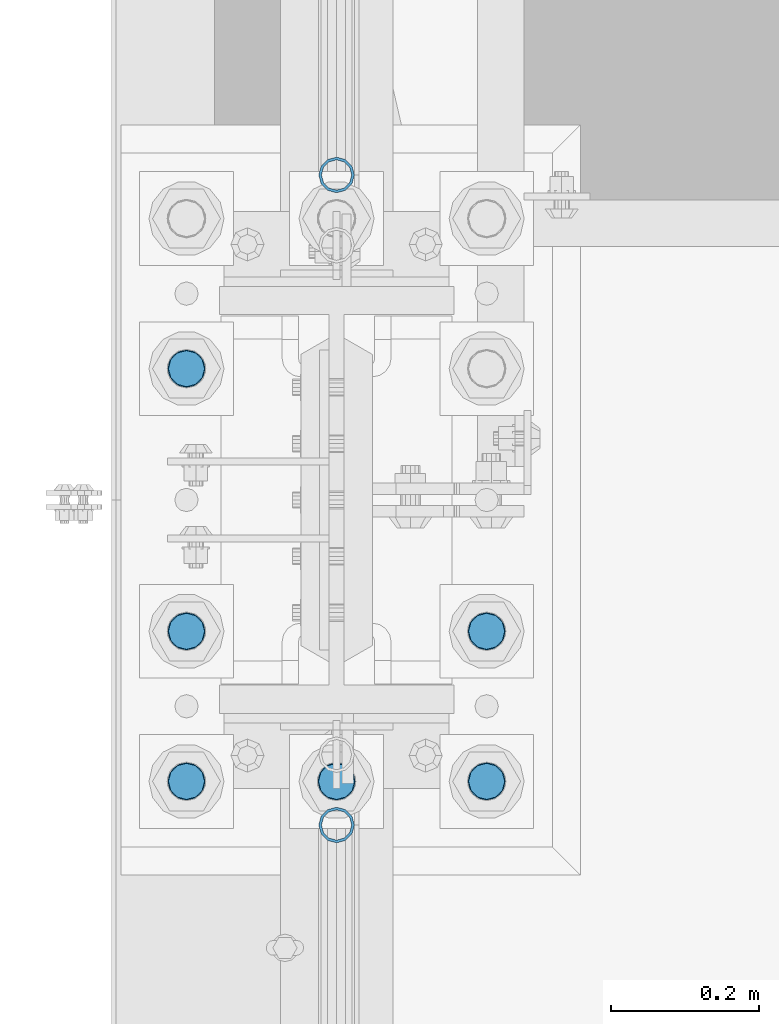
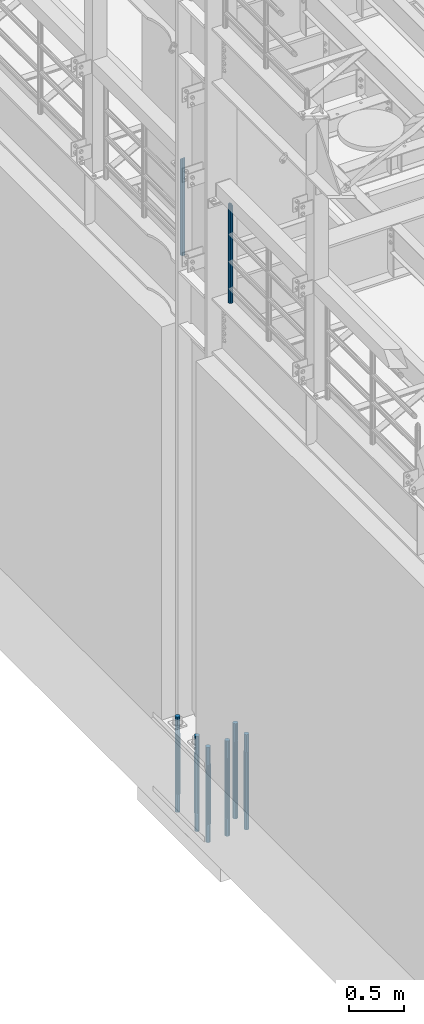
# One storey, part 687 of 1876: 8 columns, 3 elements without a shape of their own.
"""IFC2X3 building model written with IfcOpenShell, lengths in millimetres."""

from ifc_helpers import new_model, si_unit, frame, origin_with_axes, place, context, subcontext, project, spatial, faceted_brep, material, type_object, element, aggregate, save


model = new_model("IFC2X3")

# Units and contexts
model_context = context("Model", 3, precision=1e-05, world=origin_with_axes())
body_context = subcontext(model_context, "Body", "Model", "MODEL_VIEW")
ifc_project = project(units=[si_unit("LENGTHUNIT", "METRE", prefix="MILLI"), si_unit("AREAUNIT", "SQUARE_METRE"), si_unit("VOLUMEUNIT", "CUBIC_METRE"), si_unit("MASSUNIT", "GRAM", prefix="KILO"), si_unit("TIMEUNIT", "SECOND"), si_unit("PLANEANGLEUNIT", "RADIAN"), si_unit("SOLIDANGLEUNIT", "STERADIAN"), si_unit("THERMODYNAMICTEMPERATUREUNIT", "DEGREE_CELSIUS"), si_unit("LUMINOUSINTENSITYUNIT", "LUMEN")], contexts=[model_context])

# Site, building, storey
site_placement = place(None, origin_with_axes())
site = spatial("IfcSite", under=ifc_project, at=site_placement, CompositionType="ELEMENT")
building_placement = place(site_placement, origin_with_axes())
building = spatial("IfcBuilding", under=site, at=building_placement, Name="Undefined", CompositionType="ELEMENT")
storey_placement = place(building_placement, origin_with_axes())
storey = spatial("IfcBuildingStorey", under=building, at=storey_placement, Name="Undefined", CompositionType="ELEMENT", Elevation=0.0)

# Assembly, column
assembly_1_placement = place(storey_placement, origin_with_axes())
assembly_1 = element("IfcElementAssembly", 1, at=assembly_1_placement, inside=storey, Name="RAIL", AssemblyPlace="NOTDEFINED", PredefinedType="RIGID_FRAME")
ifc_material_1 = material()
column_type_1 = type_object("IfcColumnType", Name="PIPE1-1/2SCH40", PredefinedType="NOTDEFINED")
column_1_placement = place(assembly_1_placement, frame((-1.81898940354586e-12, 1964.055, 5130.8), z_axis=(0.0, 1.0, 0.0), x_axis=(0.0, 0.0, 1.0)))
column_1 = element("IfcColumn", 2, at=column_1_placement, type_object=column_type_1, material=ifc_material_1, Name="POST", ObjectType="PIPE1-1/2SCH40", context=body_context, shape_type="Brep", body=[
    faceted_brep([(0.0, -20.4469999999999, 0.0), (0.0, -17.7076214311803, 10.2235000000001), (1066.1015, -17.7076214311803, 10.2235000000001), (1076.325, -20.4469999999999, 0.0), (0.0, -10.2235000000001, 17.7076214311801), (1058.61737856882, -10.2235000000001, 17.7076214311801), (-1.45519152283669e-11, 0.0, 20.4470000000001), (1055.878, 0.0, 20.4470000000001), (0.0, 10.2235000000001, 17.7076214311801), (1058.61737856882, 10.2235000000001, 17.7076214311801), (0.0, 17.7076214311803, 10.2235000000001), (1066.1015, 17.7076214311803, 10.2235000000001), (0.0, 20.4469999999999, 0.0), (1076.325, 20.4469999999999, 0.0), (0.0, 17.7076214311803, -10.2235000000001), (1086.5485, 17.7076214311803, -10.2235000000001), (0.0, 10.2235000000001, -17.7076214311801), (1094.03262143118, 10.2235000000001, -17.7076214311801), (-1.45519152283669e-11, 0.0, -20.4470000000001), (1096.772, 0.0, -20.4470000000001), (0.0, -10.2235000000001, -17.7076214311801), (1094.03262143118, -10.2235000000001, -17.7076214311801), (0.0, -17.7076214311803, -10.2235000000001), (1086.5485, -17.7076214311803, -10.2235000000001), (0.0, -24.1299999999992, 0.0), (0.0, -20.8971929933184, -12.0649999999996), (1088.39, -20.8971929933184, -12.0649999999996), (1076.325, -24.1300000000001, 0.0), (0.0, -12.0650000000001, -20.8971929933186), (1097.22219299332, -12.0650000000001, -20.8971929933186), (-1.45519152283669e-11, 0.0, -24.130000000001), (1100.455, 0.0, -24.1300000000001), (0.0, 12.0650000000001, -20.8971929933186), (1097.22219299332, 12.0650000000001, -20.8971929933186), (0.0, 20.8971929933184, -12.0649999999996), (1088.39, 20.8971929933184, -12.0649999999996), (0.0, 24.1299999999992, 0.0), (1076.325, 24.1300000000001, 0.0), (0.0, 20.8971929933184, 12.0649999999996), (1064.26, 20.8971929933184, 12.0649999999996), (0.0, 12.0650000000001, 20.8971929933186), (1055.42780700668, 12.0650000000001, 20.8971929933186), (-1.45519152283669e-11, 0.0, 24.130000000001), (1052.195, 0.0, 24.1300000000001), (0.0, -12.0650000000001, 20.8971929933186), (1055.42780700668, -12.0650000000001, 20.8971929933186), (0.0, -20.8971929933184, 12.0649999999996), (1064.26, -20.8971929933184, 12.0649999999996)], [[[0, 1, 2, 3]], [[1, 4, 5, 2]], [[4, 6, 7, 5]], [[6, 8, 9, 7]], [[8, 10, 11, 9]], [[10, 12, 13, 11]], [[12, 14, 15, 13]], [[14, 16, 17, 15]], [[16, 18, 19, 17]], [[18, 20, 21, 19]], [[20, 22, 23, 21]], [[22, 0, 3, 23]], [[24, 25, 26, 27]], [[25, 28, 29, 26]], [[28, 30, 31, 29]], [[30, 32, 33, 31]], [[32, 34, 35, 33]], [[34, 36, 37, 35]], [[36, 38, 39, 37]], [[38, 40, 41, 39]], [[40, 42, 43, 41]], [[42, 44, 45, 43]], [[44, 46, 47, 45]], [[46, 24, 27, 47]], [[29, 31, 33, 35, 37, 39, 41, 43, 45, 47, 27, 26], [5, 7, 9, 11, 13, 15, 17, 19, 21, 23, 3, 2]], [[46, 44, 42, 40, 38, 36, 34, 32, 30, 28, 25, 24], [22, 20, 18, 16, 14, 12, 10, 8, 6, 4, 1, 0]]]),
])
aggregate(assembly_1, [column_1])

assembly_2_placement = place(storey_placement, origin_with_axes())
assembly_2 = element("IfcElementAssembly", 3, at=assembly_2_placement, inside=storey, Name="RAIL", AssemblyPlace="NOTDEFINED", PredefinedType="RIGID_FRAME")
column_2_placement = place(assembly_2_placement, frame((-1.81898940354586e-12, 1083.9096633614, 5130.81182459913), z_axis=(0.0, 1.0, 0.0), x_axis=(0.0, 0.0, 1.0)))
column_2 = element("IfcColumn", 4, at=column_2_placement, type_object=column_type_1, material=ifc_material_1, Name="POST", ObjectType="PIPE1-1/2SCH40", context=body_context, shape_type="Brep", body=[
    faceted_brep([(0.0, -20.4469999999999, 0.0), (0.0, -17.7076214311803, 10.2235000000001), (1086.54858618554, -17.7076214311801, 10.2235000000001), (1076.325, -20.4469999999999, 0.0), (0.0, -10.2235000000001, 17.7076214311801), (1094.03277070908, -10.2235000000001, 17.7076214311801), (-1.45519152283669e-11, 0.0, 20.4470000000001), (1096.7721723713, 0.0, 20.4470000000001), (0.0, 10.2235000000001, 17.7076214311801), (1094.03277070908, 10.2235000000001, 17.7076214311801), (0.0, 17.7076214311803, 10.2235000000001), (1086.54858618554, 17.7076214311801, 10.2235000000001), (0.0, 20.4469999999999, 0.0), (1076.325, 20.4469999999999, 0.0), (0.0, 17.7076214311803, -10.2235000000001), (1066.101413814, 17.7076214311801, -10.2235000000001), (0.0, 10.2235000000001, -17.7076214311801), (1058.61722929046, 10.2235000000001, -17.7076214311801), (-1.45519152283669e-11, 0.0, -20.4470000000001), (1055.87782762823, 0.0, -20.4470000000001), (0.0, -10.2235000000001, -17.7076214311801), (1058.61722929046, -10.2235000000001, -17.7076214311801), (0.0, -17.7076214311803, -10.2235000000001), (1066.101413814, -17.7076214311801, -10.2235000000001), (0.0, -24.1299999999992, 0.0), (0.0, -20.8971929933184, -12.0649999999996), (1064.25989828953, -20.8971929933186, -12.0650000000001), (1076.325, -24.1300000000001, 0.0), (0.0, -12.0650000000001, -20.8971929933186), (1055.42763084051, -12.0649999999996, -20.8971929933186), (-1.45519152283669e-11, 0.0, -24.130000000001), (1052.19479658115, 0.0, -24.1300000000001), (0.0, 12.0650000000001, -20.8971929933186), (1055.42763084051, 12.0649999999996, -20.8971929933186), (0.0, 20.8971929933184, -12.0649999999996), (1064.25989828953, 20.8971929933186, -12.0650000000001), (0.0, 24.1299999999992, 0.0), (1076.325, 24.1300000000001, 0.0), (0.0, 20.8971929933184, 12.0649999999996), (1088.39010170968, 20.8971929933186, 12.0649999999996), (0.0, 12.0650000000001, 20.8971929933186), (1097.22236915982, 12.0649999999996, 20.8971929933186), (-1.45519152283669e-11, 0.0, 24.130000000001), (1100.45520341959, 0.0, 24.1300000000001), (0.0, -12.0650000000001, 20.8971929933186), (1097.22236915982, -12.0649999999996, 20.8971929933186), (0.0, -20.8971929933184, 12.0649999999996), (1088.39010170968, -20.8971929933186, 12.0649999999996)], [[[0, 1, 2, 3]], [[1, 4, 5, 2]], [[4, 6, 7, 5]], [[6, 8, 9, 7]], [[8, 10, 11, 9]], [[10, 12, 13, 11]], [[12, 14, 15, 13]], [[14, 16, 17, 15]], [[16, 18, 19, 17]], [[18, 20, 21, 19]], [[20, 22, 23, 21]], [[22, 0, 3, 23]], [[24, 25, 26, 27]], [[25, 28, 29, 26]], [[28, 30, 31, 29]], [[30, 32, 33, 31]], [[32, 34, 35, 33]], [[34, 36, 37, 35]], [[36, 38, 39, 37]], [[38, 40, 41, 39]], [[40, 42, 43, 41]], [[42, 44, 45, 43]], [[44, 46, 47, 45]], [[46, 24, 27, 47]], [[29, 31, 33, 35, 37, 39, 41, 43, 45, 47, 27, 26], [5, 7, 9, 11, 13, 15, 17, 19, 21, 23, 3, 2]], [[46, 44, 42, 40, 38, 36, 34, 32, 30, 28, 25, 24], [22, 20, 18, 16, 14, 12, 10, 8, 6, 4, 1, 0]]]),
])
aggregate(assembly_2, [column_2])

# Assembly, columns
assembly_3_placement = place(storey_placement, origin_with_axes())
assembly_3 = element("IfcElementAssembly", 5, at=assembly_3_placement, inside=storey, Name="TEMPLATE", AssemblyPlace="NOTDEFINED", PredefinedType="RIGID_FRAME")
ifc_material_2 = material(Name="STEEL/F1554-GR.105")
column_type_2 = type_object("IfcColumnType", PredefinedType="NOTDEFINED")
column_3_placement = place(assembly_3_placement, frame((-203.2, 1143.0, 0.0), z_axis=(0.0, -1.0, 0.0), x_axis=(0.0, 0.0, -1.0)))
column_3 = element("IfcColumn", 6, at=column_3_placement, type_object=column_type_2, material=ifc_material_2, Name="ANCHOR_BOLTS", context=body_context, shape_type="Brep", body=[
    faceted_brep([(-196.85, -21.217622392719, 12.25), (-196.85, -12.25, 21.2176223927188), (-196.85, 0.0, 24.5), (-196.85, 12.25, 21.2176223927188), (-196.85, 21.217622392719, 12.25), (-196.85, 24.5, 0.0), (-196.85, 21.217622392719, -12.25), (-196.85, 12.25, -21.2176223927188), (-196.85, 0.0, -24.5), (-196.85, -12.25, -21.2176223927188), (-196.85, -21.217622392719, -12.25), (-196.85, -24.5, 0.0), (0.0, 24.5, 0.0), (0.0, 21.217622392719, -12.25), (0.0, 12.25, -21.2176223927188), (0.0, 0.0, -24.5), (0.0, -12.25, -21.2176223927188), (0.0, -21.217622392719, -12.25), (0.0, -24.5, 0.0), (0.0, -21.217622392719, 12.25), (0.0, -12.25, 21.2176223927188), (0.0, 0.0, 24.5), (0.0, 12.25, 21.2176223927188), (0.0, 21.217622392719, 12.25), (0.0, -23.4665401257871, 9.7201591820733), (0.0, -17.9605122421381, 17.9605122421383), (0.0, -9.72015918207308, 23.4665401257867), (0.0, 0.0, 25.4000000000001), (0.0, 9.72015918207308, 23.4665401257867), (0.0, 17.9605122421381, 17.9605122421383), (0.0, 23.4665401257871, 9.7201591820733), (0.0, 25.3999996185339, 9.09494701772928e-13), (0.0, 23.4665401257871, -9.7201591820733), (0.0, 17.9605122421381, -17.9605122421383), (0.0, 9.72015918207308, -23.4665401257867), (0.0, 0.0, -25.4000000000001), (0.0, -9.72015918207308, -23.4665401257867), (0.0, -17.9605122421381, -17.9605122421383), (0.0, -23.4665401257871, -9.7201591820733), (0.0, -25.3999996185375, 0.0), (673.1, -25.3999999999996, 0.0), (673.1, -23.4665401257871, 9.7201591820733), (673.1, -17.9605122421381, 17.9605122421383), (673.1, -9.72015918207308, 23.4665401257867), (673.1, 0.0, 25.4000000000001), (673.1, 9.72015918207308, 23.4665401257867), (673.1, 17.9605122421381, 17.9605122421383), (673.1, 23.4665401257871, 9.7201591820733), (673.1, 25.3999999999996, 0.0), (673.1, 23.4665401257871, -9.7201591820733), (673.1, 17.9605122421381, -17.9605122421383), (673.1, 9.72015918207308, -23.4665401257867), (673.1, 0.0, -25.4000000000001), (673.1, -9.72015918207308, -23.4665401257867), (673.1, -17.9605122421381, -17.9605122421383), (673.1, -23.4665401257871, -9.7201591820733), (673.1, -12.25, 21.2176223927188), (673.1, 0.0, 24.5), (673.1, 12.25, 21.2176223927188), (673.1, 21.217622392719, 12.25), (673.1, 24.5, 0.0), (673.1, 21.217622392719, -12.25), (673.1, 12.25, -21.2176223927188), (673.1, 0.0, -24.5), (673.1, -12.25, -21.2176223927188), (673.1, -21.217622392719, -12.25), (673.1, -24.5, 0.0), (673.1, -21.217622392719, 12.25), (869.95, -12.25, -21.2176223927188), (869.95, 0.0, -24.5), (869.95, 12.25, -21.2176223927188), (869.95, 21.217622392719, -12.25), (869.95, 24.5, 0.0), (869.95, 21.217622392719, 12.25), (869.95, 12.25, 21.2176223927188), (869.95, 0.0, 24.5), (869.95, -12.25, 21.2176223927188), (869.95, -21.217622392719, 12.25), (869.95, -24.5, 0.0), (869.95, -21.217622392719, -12.25)], [[[0, 1, 2, 3, 4, 5, 6, 7, 8, 9, 10, 11]], [[6, 5, 12, 13]], [[7, 6, 13, 14]], [[8, 7, 14, 15]], [[9, 8, 15, 16]], [[10, 9, 16, 17]], [[11, 10, 17, 18]], [[0, 11, 18, 19]], [[1, 0, 19, 20]], [[2, 1, 20, 21]], [[3, 2, 21, 22]], [[4, 3, 22, 23]], [[5, 4, 23, 12]], [[24, 25, 26, 27, 28, 29, 30, 31, 32, 33, 34, 35, 36, 37, 38, 39], [22, 21, 20, 19, 18, 17, 16, 15, 14, 13, 12, 23]], [[24, 39, 40, 41]], [[25, 24, 41, 42]], [[26, 25, 42, 43]], [[27, 26, 43, 44]], [[28, 27, 44, 45]], [[29, 28, 45, 46]], [[30, 29, 46, 47]], [[31, 30, 47, 48]], [[32, 31, 48, 49]], [[33, 32, 49, 50]], [[34, 33, 50, 51]], [[35, 34, 51, 52]], [[36, 35, 52, 53]], [[37, 36, 53, 54]], [[38, 37, 54, 55]], [[39, 38, 55, 40]], [[54, 53, 52, 51, 50, 49, 48, 47, 46, 45, 44, 43, 42, 41, 40, 55], [56, 57, 58, 59, 60, 61, 62, 63, 64, 65, 66, 67]], [[68, 69, 70, 71, 72, 73, 74, 75, 76, 77, 78, 79]], [[76, 75, 57, 56]], [[77, 76, 56, 67]], [[78, 77, 67, 66]], [[79, 78, 66, 65]], [[68, 79, 65, 64]], [[69, 68, 64, 63]], [[70, 69, 63, 62]], [[71, 70, 62, 61]], [[72, 71, 61, 60]], [[73, 72, 60, 59]], [[74, 73, 59, 58]], [[75, 74, 58, 57]]]),
])
column_4_placement = place(assembly_3_placement, frame((0.0, 1143.0, 0.0), z_axis=(0.0, -1.0, 0.0), x_axis=(0.0, 0.0, -1.0)))
column_4 = element("IfcColumn", 7, at=column_4_placement, type_object=column_type_2, material=ifc_material_2, Name="ANCHOR_BOLTS", context=body_context, shape_type="Brep", body=[
    faceted_brep([(-196.85, -21.217622392719, 12.25), (-196.85, -12.25, 21.2176223927188), (-196.85, 0.0, 24.5), (-196.85, 12.25, 21.2176223927188), (-196.85, 21.217622392719, 12.25), (-196.85, 24.5, 0.0), (-196.85, 21.217622392719, -12.25), (-196.85, 12.25, -21.2176223927188), (-196.85, 0.0, -24.5), (-196.85, -12.25, -21.2176223927188), (-196.85, -21.217622392719, -12.25), (-196.85, -24.5, 0.0), (0.0, 24.5, 0.0), (0.0, 21.217622392719, -12.25), (0.0, 12.25, -21.2176223927188), (0.0, 0.0, -24.5), (0.0, -12.25, -21.2176223927188), (0.0, -21.217622392719, -12.25), (0.0, -24.5, 0.0), (0.0, -21.217622392719, 12.25), (0.0, -12.25, 21.2176223927188), (0.0, 0.0, 24.5), (0.0, 12.25, 21.2176223927188), (0.0, 21.217622392719, 12.25), (0.0, -23.4665401257871, 9.7201591820733), (0.0, -17.9605122421381, 17.9605122421383), (0.0, -9.72015918207308, 23.4665401257867), (0.0, 0.0, 25.4000000000001), (0.0, 9.72015918207308, 23.4665401257867), (0.0, 17.9605122421381, 17.9605122421383), (0.0, 23.4665401257871, 9.7201591820733), (0.0, 25.3999996185339, 9.09494701772928e-13), (0.0, 23.4665401257871, -9.7201591820733), (0.0, 17.9605122421381, -17.9605122421383), (0.0, 9.72015918207308, -23.4665401257867), (0.0, 0.0, -25.4000000000001), (0.0, -9.72015918207308, -23.4665401257867), (0.0, -17.9605122421381, -17.9605122421383), (0.0, -23.4665401257871, -9.7201591820733), (0.0, -25.3999996185375, 0.0), (673.1, -25.3999999999996, 0.0), (673.1, -23.4665401257871, 9.7201591820733), (673.1, -17.9605122421381, 17.9605122421383), (673.1, -9.72015918207308, 23.4665401257867), (673.1, 0.0, 25.4000000000001), (673.1, 9.72015918207308, 23.4665401257867), (673.1, 17.9605122421381, 17.9605122421383), (673.1, 23.4665401257871, 9.7201591820733), (673.1, 25.3999999999996, 0.0), (673.1, 23.4665401257871, -9.7201591820733), (673.1, 17.9605122421381, -17.9605122421383), (673.1, 9.72015918207308, -23.4665401257867), (673.1, 0.0, -25.4000000000001), (673.1, -9.72015918207308, -23.4665401257867), (673.1, -17.9605122421381, -17.9605122421383), (673.1, -23.4665401257871, -9.7201591820733), (673.1, -12.25, 21.2176223927188), (673.1, 0.0, 24.5), (673.1, 12.25, 21.2176223927188), (673.1, 21.217622392719, 12.25), (673.1, 24.5, 0.0), (673.1, 21.217622392719, -12.25), (673.1, 12.25, -21.2176223927188), (673.1, 0.0, -24.5), (673.1, -12.25, -21.2176223927188), (673.1, -21.217622392719, -12.25), (673.1, -24.5, 0.0), (673.1, -21.217622392719, 12.25), (869.95, -12.25, -21.2176223927188), (869.95, 0.0, -24.5), (869.95, 12.25, -21.2176223927188), (869.95, 21.217622392719, -12.25), (869.95, 24.5, 0.0), (869.95, 21.217622392719, 12.25), (869.95, 12.25, 21.2176223927188), (869.95, 0.0, 24.5), (869.95, -12.25, 21.2176223927188), (869.95, -21.217622392719, 12.25), (869.95, -24.5, 0.0), (869.95, -21.217622392719, -12.25)], [[[0, 1, 2, 3, 4, 5, 6, 7, 8, 9, 10, 11]], [[6, 5, 12, 13]], [[7, 6, 13, 14]], [[8, 7, 14, 15]], [[9, 8, 15, 16]], [[10, 9, 16, 17]], [[11, 10, 17, 18]], [[0, 11, 18, 19]], [[1, 0, 19, 20]], [[2, 1, 20, 21]], [[3, 2, 21, 22]], [[4, 3, 22, 23]], [[5, 4, 23, 12]], [[24, 25, 26, 27, 28, 29, 30, 31, 32, 33, 34, 35, 36, 37, 38, 39], [22, 21, 20, 19, 18, 17, 16, 15, 14, 13, 12, 23]], [[24, 39, 40, 41]], [[25, 24, 41, 42]], [[26, 25, 42, 43]], [[27, 26, 43, 44]], [[28, 27, 44, 45]], [[29, 28, 45, 46]], [[30, 29, 46, 47]], [[31, 30, 47, 48]], [[32, 31, 48, 49]], [[33, 32, 49, 50]], [[34, 33, 50, 51]], [[35, 34, 51, 52]], [[36, 35, 52, 53]], [[37, 36, 53, 54]], [[38, 37, 54, 55]], [[39, 38, 55, 40]], [[54, 53, 52, 51, 50, 49, 48, 47, 46, 45, 44, 43, 42, 41, 40, 55], [56, 57, 58, 59, 60, 61, 62, 63, 64, 65, 66, 67]], [[68, 69, 70, 71, 72, 73, 74, 75, 76, 77, 78, 79]], [[76, 75, 57, 56]], [[77, 76, 56, 67]], [[78, 77, 67, 66]], [[79, 78, 66, 65]], [[68, 79, 65, 64]], [[69, 68, 64, 63]], [[70, 69, 63, 62]], [[71, 70, 62, 61]], [[72, 71, 61, 60]], [[73, 72, 60, 59]], [[74, 73, 59, 58]], [[75, 74, 58, 57]]]),
])
column_5_placement = place(assembly_3_placement, frame((203.2, 1143.0, 0.0), z_axis=(0.0, 1.0, 0.0), x_axis=(0.0, 0.0, -1.0)))
column_5 = element("IfcColumn", 8, at=column_5_placement, type_object=column_type_2, material=ifc_material_2, Name="ANCHOR_BOLTS", context=body_context, shape_type="Brep", body=[
    faceted_brep([(-196.85, -21.217622392719, 12.25), (-196.85, -12.25, 21.2176223927188), (-196.85, 0.0, 24.5), (-196.85, 12.25, 21.2176223927188), (-196.85, 21.217622392719, 12.25), (-196.85, 24.5, 0.0), (-196.85, 21.217622392719, -12.25), (-196.85, 12.25, -21.2176223927188), (-196.85, 0.0, -24.5), (-196.85, -12.25, -21.2176223927188), (-196.85, -21.217622392719, -12.25), (-196.85, -24.5, 0.0), (0.0, 24.5, 0.0), (0.0, 21.217622392719, -12.25), (0.0, 12.25, -21.2176223927188), (0.0, 0.0, -24.5), (0.0, -12.25, -21.2176223927188), (0.0, -21.217622392719, -12.25), (0.0, -24.5, 0.0), (0.0, -21.217622392719, 12.25), (0.0, -12.25, 21.2176223927188), (0.0, 0.0, 24.5), (0.0, 12.25, 21.2176223927188), (0.0, 21.217622392719, 12.25), (0.0, -23.4665401257871, 9.7201591820733), (0.0, -17.9605122421381, 17.9605122421383), (0.0, -9.72015918207308, 23.4665401257867), (0.0, 0.0, 25.4000000000001), (0.0, 9.72015918207308, 23.4665401257867), (0.0, 17.9605122421381, 17.9605122421383), (0.0, 23.4665401257871, 9.7201591820733), (0.0, 25.3999996185339, 9.09494701772928e-13), (0.0, 23.4665401257871, -9.7201591820733), (0.0, 17.9605122421381, -17.9605122421383), (0.0, 9.72015918207308, -23.4665401257867), (0.0, 0.0, -25.4000000000001), (0.0, -9.72015918207308, -23.4665401257867), (0.0, -17.9605122421381, -17.9605122421383), (0.0, -23.4665401257871, -9.7201591820733), (0.0, -25.3999996185375, 0.0), (673.1, -25.3999999999996, 0.0), (673.1, -23.4665401257871, 9.7201591820733), (673.1, -17.9605122421381, 17.9605122421383), (673.1, -9.72015918207308, 23.4665401257867), (673.1, 0.0, 25.4000000000001), (673.1, 9.72015918207308, 23.4665401257867), (673.1, 17.9605122421381, 17.9605122421383), (673.1, 23.4665401257871, 9.7201591820733), (673.1, 25.3999999999996, 0.0), (673.1, 23.4665401257871, -9.7201591820733), (673.1, 17.9605122421381, -17.9605122421383), (673.1, 9.72015918207308, -23.4665401257867), (673.1, 0.0, -25.4000000000001), (673.1, -9.72015918207308, -23.4665401257867), (673.1, -17.9605122421381, -17.9605122421383), (673.1, -23.4665401257871, -9.7201591820733), (673.1, -12.25, 21.2176223927188), (673.1, 0.0, 24.5), (673.1, 12.25, 21.2176223927188), (673.1, 21.217622392719, 12.25), (673.1, 24.5, 0.0), (673.1, 21.217622392719, -12.25), (673.1, 12.25, -21.2176223927188), (673.1, 0.0, -24.5), (673.1, -12.25, -21.2176223927188), (673.1, -21.217622392719, -12.25), (673.1, -24.5, 0.0), (673.1, -21.217622392719, 12.25), (869.95, -12.25, -21.2176223927188), (869.95, 0.0, -24.5), (869.95, 12.25, -21.2176223927188), (869.95, 21.217622392719, -12.25), (869.95, 24.5, 0.0), (869.95, 21.217622392719, 12.25), (869.95, 12.25, 21.2176223927188), (869.95, 0.0, 24.5), (869.95, -12.25, 21.2176223927188), (869.95, -21.217622392719, 12.25), (869.95, -24.5, 0.0), (869.95, -21.217622392719, -12.25)], [[[0, 1, 2, 3, 4, 5, 6, 7, 8, 9, 10, 11]], [[6, 5, 12, 13]], [[7, 6, 13, 14]], [[8, 7, 14, 15]], [[9, 8, 15, 16]], [[10, 9, 16, 17]], [[11, 10, 17, 18]], [[0, 11, 18, 19]], [[1, 0, 19, 20]], [[2, 1, 20, 21]], [[3, 2, 21, 22]], [[4, 3, 22, 23]], [[5, 4, 23, 12]], [[24, 25, 26, 27, 28, 29, 30, 31, 32, 33, 34, 35, 36, 37, 38, 39], [22, 21, 20, 19, 18, 17, 16, 15, 14, 13, 12, 23]], [[24, 39, 40, 41]], [[25, 24, 41, 42]], [[26, 25, 42, 43]], [[27, 26, 43, 44]], [[28, 27, 44, 45]], [[29, 28, 45, 46]], [[30, 29, 46, 47]], [[31, 30, 47, 48]], [[32, 31, 48, 49]], [[33, 32, 49, 50]], [[34, 33, 50, 51]], [[35, 34, 51, 52]], [[36, 35, 52, 53]], [[37, 36, 53, 54]], [[38, 37, 54, 55]], [[39, 38, 55, 40]], [[54, 53, 52, 51, 50, 49, 48, 47, 46, 45, 44, 43, 42, 41, 40, 55], [56, 57, 58, 59, 60, 61, 62, 63, 64, 65, 66, 67]], [[68, 69, 70, 71, 72, 73, 74, 75, 76, 77, 78, 79]], [[76, 75, 57, 56]], [[77, 76, 56, 67]], [[78, 77, 67, 66]], [[79, 78, 66, 65]], [[68, 79, 65, 64]], [[69, 68, 64, 63]], [[70, 69, 63, 62]], [[71, 70, 62, 61]], [[72, 71, 61, 60]], [[73, 72, 60, 59]], [[74, 73, 59, 58]], [[75, 74, 58, 57]]]),
])
column_6_placement = place(assembly_3_placement, frame((-203.2, 1346.2, 0.0), z_axis=(0.0, -1.0, 0.0), x_axis=(0.0, 0.0, -1.0)))
column_6 = element("IfcColumn", 9, at=column_6_placement, type_object=column_type_2, material=ifc_material_2, Name="ANCHOR_BOLTS", context=body_context, shape_type="Brep", body=[
    faceted_brep([(-196.85, -21.217622392719, 12.25), (-196.85, -12.25, 21.2176223927188), (-196.85, 0.0, 24.5), (-196.85, 12.25, 21.2176223927188), (-196.85, 21.217622392719, 12.25), (-196.85, 24.5, 0.0), (-196.85, 21.217622392719, -12.25), (-196.85, 12.25, -21.2176223927188), (-196.85, 0.0, -24.5), (-196.85, -12.25, -21.2176223927188), (-196.85, -21.217622392719, -12.25), (-196.85, -24.5, 0.0), (0.0, 24.5, 0.0), (0.0, 21.217622392719, -12.25), (0.0, 12.25, -21.2176223927188), (0.0, 0.0, -24.5), (0.0, -12.25, -21.2176223927188), (0.0, -21.217622392719, -12.25), (0.0, -24.5, 0.0), (0.0, -21.217622392719, 12.25), (0.0, -12.25, 21.2176223927188), (0.0, 0.0, 24.5), (0.0, 12.25, 21.2176223927188), (0.0, 21.217622392719, 12.25), (0.0, -23.4665401257871, 9.7201591820733), (0.0, -17.9605122421381, 17.9605122421383), (0.0, -9.72015918207308, 23.4665401257867), (0.0, 0.0, 25.4000000000001), (0.0, 9.72015918207308, 23.4665401257867), (0.0, 17.9605122421381, 17.9605122421383), (0.0, 23.4665401257871, 9.7201591820733), (0.0, 25.3999996185339, 9.09494701772928e-13), (0.0, 23.4665401257871, -9.7201591820733), (0.0, 17.9605122421381, -17.9605122421383), (0.0, 9.72015918207308, -23.4665401257867), (0.0, 0.0, -25.4000000000001), (0.0, -9.72015918207308, -23.4665401257867), (0.0, -17.9605122421381, -17.9605122421383), (0.0, -23.4665401257871, -9.7201591820733), (0.0, -25.3999996185375, 0.0), (673.1, -25.3999999999996, 0.0), (673.1, -23.4665401257871, 9.7201591820733), (673.1, -17.9605122421381, 17.9605122421383), (673.1, -9.72015918207308, 23.4665401257867), (673.1, 0.0, 25.4000000000001), (673.1, 9.72015918207308, 23.4665401257867), (673.1, 17.9605122421381, 17.9605122421383), (673.1, 23.4665401257871, 9.7201591820733), (673.1, 25.3999999999996, 0.0), (673.1, 23.4665401257871, -9.7201591820733), (673.1, 17.9605122421381, -17.9605122421383), (673.1, 9.72015918207308, -23.4665401257867), (673.1, 0.0, -25.4000000000001), (673.1, -9.72015918207308, -23.4665401257867), (673.1, -17.9605122421381, -17.9605122421383), (673.1, -23.4665401257871, -9.7201591820733), (673.1, -12.25, 21.2176223927188), (673.1, 0.0, 24.5), (673.1, 12.25, 21.2176223927188), (673.1, 21.217622392719, 12.25), (673.1, 24.5, 0.0), (673.1, 21.217622392719, -12.25), (673.1, 12.25, -21.2176223927188), (673.1, 0.0, -24.5), (673.1, -12.25, -21.2176223927188), (673.1, -21.217622392719, -12.25), (673.1, -24.5, 0.0), (673.1, -21.217622392719, 12.25), (869.95, -12.25, -21.2176223927188), (869.95, 0.0, -24.5), (869.95, 12.25, -21.2176223927188), (869.95, 21.217622392719, -12.25), (869.95, 24.5, 0.0), (869.95, 21.217622392719, 12.25), (869.95, 12.25, 21.2176223927188), (869.95, 0.0, 24.5), (869.95, -12.25, 21.2176223927188), (869.95, -21.217622392719, 12.25), (869.95, -24.5, 0.0), (869.95, -21.217622392719, -12.25)], [[[0, 1, 2, 3, 4, 5, 6, 7, 8, 9, 10, 11]], [[6, 5, 12, 13]], [[7, 6, 13, 14]], [[8, 7, 14, 15]], [[9, 8, 15, 16]], [[10, 9, 16, 17]], [[11, 10, 17, 18]], [[0, 11, 18, 19]], [[1, 0, 19, 20]], [[2, 1, 20, 21]], [[3, 2, 21, 22]], [[4, 3, 22, 23]], [[5, 4, 23, 12]], [[24, 25, 26, 27, 28, 29, 30, 31, 32, 33, 34, 35, 36, 37, 38, 39], [22, 21, 20, 19, 18, 17, 16, 15, 14, 13, 12, 23]], [[24, 39, 40, 41]], [[25, 24, 41, 42]], [[26, 25, 42, 43]], [[27, 26, 43, 44]], [[28, 27, 44, 45]], [[29, 28, 45, 46]], [[30, 29, 46, 47]], [[31, 30, 47, 48]], [[32, 31, 48, 49]], [[33, 32, 49, 50]], [[34, 33, 50, 51]], [[35, 34, 51, 52]], [[36, 35, 52, 53]], [[37, 36, 53, 54]], [[38, 37, 54, 55]], [[39, 38, 55, 40]], [[54, 53, 52, 51, 50, 49, 48, 47, 46, 45, 44, 43, 42, 41, 40, 55], [56, 57, 58, 59, 60, 61, 62, 63, 64, 65, 66, 67]], [[68, 69, 70, 71, 72, 73, 74, 75, 76, 77, 78, 79]], [[76, 75, 57, 56]], [[77, 76, 56, 67]], [[78, 77, 67, 66]], [[79, 78, 66, 65]], [[68, 79, 65, 64]], [[69, 68, 64, 63]], [[70, 69, 63, 62]], [[71, 70, 62, 61]], [[72, 71, 61, 60]], [[73, 72, 60, 59]], [[74, 73, 59, 58]], [[75, 74, 58, 57]]]),
])
column_7_placement = place(assembly_3_placement, frame((203.2, 1346.2, 0.0), z_axis=(0.0, 1.0, 0.0), x_axis=(0.0, 0.0, -1.0)))
column_7 = element("IfcColumn", 10, at=column_7_placement, type_object=column_type_2, material=ifc_material_2, Name="ANCHOR_BOLTS", context=body_context, shape_type="Brep", body=[
    faceted_brep([(-196.85, -21.217622392719, 12.25), (-196.85, -12.25, 21.2176223927188), (-196.85, 0.0, 24.5), (-196.85, 12.25, 21.2176223927188), (-196.85, 21.217622392719, 12.25), (-196.85, 24.5, 0.0), (-196.85, 21.217622392719, -12.25), (-196.85, 12.25, -21.2176223927188), (-196.85, 0.0, -24.5), (-196.85, -12.25, -21.2176223927188), (-196.85, -21.217622392719, -12.25), (-196.85, -24.5, 0.0), (0.0, 24.5, 0.0), (0.0, 21.217622392719, -12.25), (0.0, 12.25, -21.2176223927188), (0.0, 0.0, -24.5), (0.0, -12.25, -21.2176223927188), (0.0, -21.217622392719, -12.25), (0.0, -24.5, 0.0), (0.0, -21.217622392719, 12.25), (0.0, -12.25, 21.2176223927188), (0.0, 0.0, 24.5), (0.0, 12.25, 21.2176223927188), (0.0, 21.217622392719, 12.25), (0.0, -23.4665401257871, 9.7201591820733), (0.0, -17.9605122421381, 17.9605122421383), (0.0, -9.72015918207308, 23.4665401257867), (0.0, 0.0, 25.4000000000001), (0.0, 9.72015918207308, 23.4665401257867), (0.0, 17.9605122421381, 17.9605122421383), (0.0, 23.4665401257871, 9.7201591820733), (0.0, 25.3999996185339, 9.09494701772928e-13), (0.0, 23.4665401257871, -9.7201591820733), (0.0, 17.9605122421381, -17.9605122421383), (0.0, 9.72015918207308, -23.4665401257867), (0.0, 0.0, -25.4000000000001), (0.0, -9.72015918207308, -23.4665401257867), (0.0, -17.9605122421381, -17.9605122421383), (0.0, -23.4665401257871, -9.7201591820733), (0.0, -25.3999996185375, 0.0), (673.1, -25.3999999999996, 0.0), (673.1, -23.4665401257871, 9.7201591820733), (673.1, -17.9605122421381, 17.9605122421383), (673.1, -9.72015918207308, 23.4665401257867), (673.1, 0.0, 25.4000000000001), (673.1, 9.72015918207308, 23.4665401257867), (673.1, 17.9605122421381, 17.9605122421383), (673.1, 23.4665401257871, 9.7201591820733), (673.1, 25.3999999999996, 0.0), (673.1, 23.4665401257871, -9.7201591820733), (673.1, 17.9605122421381, -17.9605122421383), (673.1, 9.72015918207308, -23.4665401257867), (673.1, 0.0, -25.4000000000001), (673.1, -9.72015918207308, -23.4665401257867), (673.1, -17.9605122421381, -17.9605122421383), (673.1, -23.4665401257871, -9.7201591820733), (673.1, -12.25, 21.2176223927188), (673.1, 0.0, 24.5), (673.1, 12.25, 21.2176223927188), (673.1, 21.217622392719, 12.25), (673.1, 24.5, 0.0), (673.1, 21.217622392719, -12.25), (673.1, 12.25, -21.2176223927188), (673.1, 0.0, -24.5), (673.1, -12.25, -21.2176223927188), (673.1, -21.217622392719, -12.25), (673.1, -24.5, 0.0), (673.1, -21.217622392719, 12.25), (869.95, -12.25, -21.2176223927188), (869.95, 0.0, -24.5), (869.95, 12.25, -21.2176223927188), (869.95, 21.217622392719, -12.25), (869.95, 24.5, 0.0), (869.95, 21.217622392719, 12.25), (869.95, 12.25, 21.2176223927188), (869.95, 0.0, 24.5), (869.95, -12.25, 21.2176223927188), (869.95, -21.217622392719, 12.25), (869.95, -24.5, 0.0), (869.95, -21.217622392719, -12.25)], [[[0, 1, 2, 3, 4, 5, 6, 7, 8, 9, 10, 11]], [[6, 5, 12, 13]], [[7, 6, 13, 14]], [[8, 7, 14, 15]], [[9, 8, 15, 16]], [[10, 9, 16, 17]], [[11, 10, 17, 18]], [[0, 11, 18, 19]], [[1, 0, 19, 20]], [[2, 1, 20, 21]], [[3, 2, 21, 22]], [[4, 3, 22, 23]], [[5, 4, 23, 12]], [[24, 25, 26, 27, 28, 29, 30, 31, 32, 33, 34, 35, 36, 37, 38, 39], [22, 21, 20, 19, 18, 17, 16, 15, 14, 13, 12, 23]], [[24, 39, 40, 41]], [[25, 24, 41, 42]], [[26, 25, 42, 43]], [[27, 26, 43, 44]], [[28, 27, 44, 45]], [[29, 28, 45, 46]], [[30, 29, 46, 47]], [[31, 30, 47, 48]], [[32, 31, 48, 49]], [[33, 32, 49, 50]], [[34, 33, 50, 51]], [[35, 34, 51, 52]], [[36, 35, 52, 53]], [[37, 36, 53, 54]], [[38, 37, 54, 55]], [[39, 38, 55, 40]], [[54, 53, 52, 51, 50, 49, 48, 47, 46, 45, 44, 43, 42, 41, 40, 55], [56, 57, 58, 59, 60, 61, 62, 63, 64, 65, 66, 67]], [[68, 69, 70, 71, 72, 73, 74, 75, 76, 77, 78, 79]], [[76, 75, 57, 56]], [[77, 76, 56, 67]], [[78, 77, 67, 66]], [[79, 78, 66, 65]], [[68, 79, 65, 64]], [[69, 68, 64, 63]], [[70, 69, 63, 62]], [[71, 70, 62, 61]], [[72, 71, 61, 60]], [[73, 72, 60, 59]], [[74, 73, 59, 58]], [[75, 74, 58, 57]]]),
])
column_8_placement = place(assembly_3_placement, frame((-203.2, 1701.8, 0.0), z_axis=(0.0, -1.0, 0.0), x_axis=(0.0, 0.0, -1.0)))
column_8 = element("IfcColumn", 11, at=column_8_placement, type_object=column_type_2, material=ifc_material_2, Name="ANCHOR_BOLTS", context=body_context, shape_type="Brep", body=[
    faceted_brep([(-196.85, -21.217622392719, 12.25), (-196.85, -12.25, 21.2176223927188), (-196.85, 0.0, 24.5), (-196.85, 12.25, 21.2176223927188), (-196.85, 21.217622392719, 12.25), (-196.85, 24.5, 0.0), (-196.85, 21.217622392719, -12.25), (-196.85, 12.25, -21.2176223927188), (-196.85, 0.0, -24.5), (-196.85, -12.25, -21.2176223927188), (-196.85, -21.217622392719, -12.25), (-196.85, -24.5, 0.0), (0.0, 24.5, 0.0), (0.0, 21.217622392719, -12.25), (0.0, 12.25, -21.2176223927188), (0.0, 0.0, -24.5), (0.0, -12.25, -21.2176223927188), (0.0, -21.217622392719, -12.25), (0.0, -24.5, 0.0), (0.0, -21.217622392719, 12.25), (0.0, -12.25, 21.2176223927188), (0.0, 0.0, 24.5), (0.0, 12.25, 21.2176223927188), (0.0, 21.217622392719, 12.25), (0.0, -23.4665401257871, 9.7201591820733), (0.0, -17.9605122421381, 17.9605122421383), (0.0, -9.72015918207308, 23.4665401257867), (0.0, 0.0, 25.4000000000001), (0.0, 9.72015918207308, 23.4665401257867), (0.0, 17.9605122421381, 17.9605122421383), (0.0, 23.4665401257871, 9.7201591820733), (0.0, 25.3999996185339, 9.09494701772928e-13), (0.0, 23.4665401257871, -9.7201591820733), (0.0, 17.9605122421381, -17.9605122421383), (0.0, 9.72015918207308, -23.4665401257867), (0.0, 0.0, -25.4000000000001), (0.0, -9.72015918207308, -23.4665401257867), (0.0, -17.9605122421381, -17.9605122421383), (0.0, -23.4665401257871, -9.7201591820733), (0.0, -25.3999996185375, 0.0), (673.1, -25.3999999999996, 0.0), (673.1, -23.4665401257871, 9.7201591820733), (673.1, -17.9605122421381, 17.9605122421383), (673.1, -9.72015918207308, 23.4665401257867), (673.1, 0.0, 25.4000000000001), (673.1, 9.72015918207308, 23.4665401257867), (673.1, 17.9605122421381, 17.9605122421383), (673.1, 23.4665401257871, 9.7201591820733), (673.1, 25.3999999999996, 0.0), (673.1, 23.4665401257871, -9.7201591820733), (673.1, 17.9605122421381, -17.9605122421383), (673.1, 9.72015918207308, -23.4665401257867), (673.1, 0.0, -25.4000000000001), (673.1, -9.72015918207308, -23.4665401257867), (673.1, -17.9605122421381, -17.9605122421383), (673.1, -23.4665401257871, -9.7201591820733), (673.1, -12.25, 21.2176223927188), (673.1, 0.0, 24.5), (673.1, 12.25, 21.2176223927188), (673.1, 21.217622392719, 12.25), (673.1, 24.5, 0.0), (673.1, 21.217622392719, -12.25), (673.1, 12.25, -21.2176223927188), (673.1, 0.0, -24.5), (673.1, -12.25, -21.2176223927188), (673.1, -21.217622392719, -12.25), (673.1, -24.5, 0.0), (673.1, -21.217622392719, 12.25), (869.95, -12.25, -21.2176223927188), (869.95, 0.0, -24.5), (869.95, 12.25, -21.2176223927188), (869.95, 21.217622392719, -12.25), (869.95, 24.5, 0.0), (869.95, 21.217622392719, 12.25), (869.95, 12.25, 21.2176223927188), (869.95, 0.0, 24.5), (869.95, -12.25, 21.2176223927188), (869.95, -21.217622392719, 12.25), (869.95, -24.5, 0.0), (869.95, -21.217622392719, -12.25)], [[[0, 1, 2, 3, 4, 5, 6, 7, 8, 9, 10, 11]], [[6, 5, 12, 13]], [[7, 6, 13, 14]], [[8, 7, 14, 15]], [[9, 8, 15, 16]], [[10, 9, 16, 17]], [[11, 10, 17, 18]], [[0, 11, 18, 19]], [[1, 0, 19, 20]], [[2, 1, 20, 21]], [[3, 2, 21, 22]], [[4, 3, 22, 23]], [[5, 4, 23, 12]], [[24, 25, 26, 27, 28, 29, 30, 31, 32, 33, 34, 35, 36, 37, 38, 39], [22, 21, 20, 19, 18, 17, 16, 15, 14, 13, 12, 23]], [[24, 39, 40, 41]], [[25, 24, 41, 42]], [[26, 25, 42, 43]], [[27, 26, 43, 44]], [[28, 27, 44, 45]], [[29, 28, 45, 46]], [[30, 29, 46, 47]], [[31, 30, 47, 48]], [[32, 31, 48, 49]], [[33, 32, 49, 50]], [[34, 33, 50, 51]], [[35, 34, 51, 52]], [[36, 35, 52, 53]], [[37, 36, 53, 54]], [[38, 37, 54, 55]], [[39, 38, 55, 40]], [[54, 53, 52, 51, 50, 49, 48, 47, 46, 45, 44, 43, 42, 41, 40, 55], [56, 57, 58, 59, 60, 61, 62, 63, 64, 65, 66, 67]], [[68, 69, 70, 71, 72, 73, 74, 75, 76, 77, 78, 79]], [[76, 75, 57, 56]], [[77, 76, 56, 67]], [[78, 77, 67, 66]], [[79, 78, 66, 65]], [[68, 79, 65, 64]], [[69, 68, 64, 63]], [[70, 69, 63, 62]], [[71, 70, 62, 61]], [[72, 71, 61, 60]], [[73, 72, 60, 59]], [[74, 73, 59, 58]], [[75, 74, 58, 57]]]),
])
aggregate(assembly_3, [column_3, column_4, column_5, column_6, column_7, column_8])

save(model, "model.ifc")
